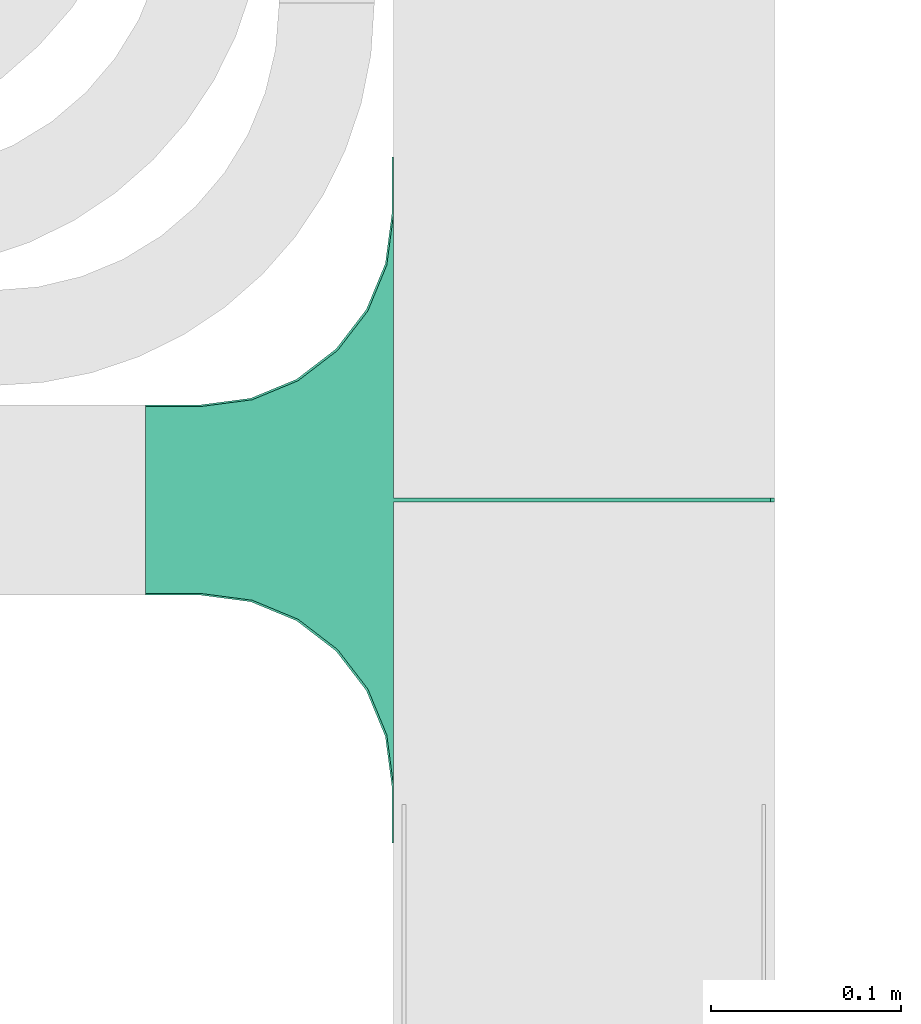
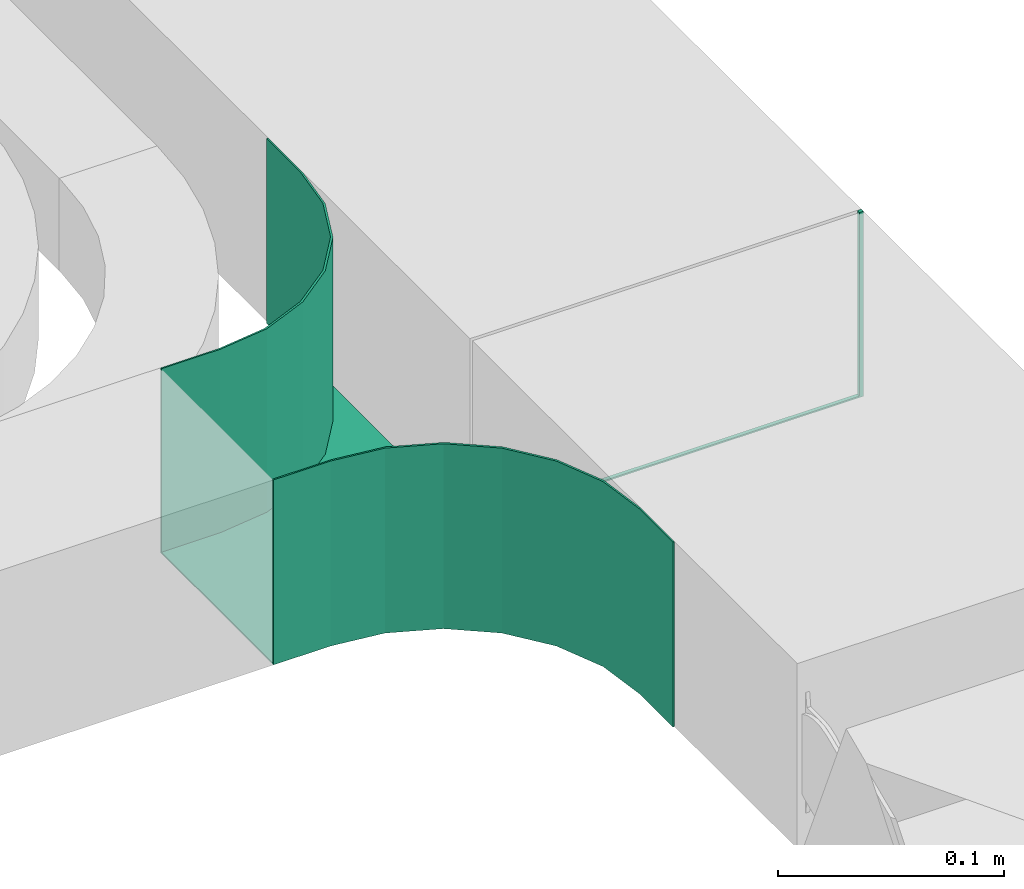
# One storey, part 25 of 25: 1 flow fitting.
"""IFC2X3 building model written with IfcOpenShell, lengths in millimetres."""

from ifc_helpers import new_model, entity, si_unit, converted_unit, derived_unit, direction, frame, origin, place, context, subcontext, project, spatial, faceted_brep, source, transform, mapped, material, type_object, type_shapes, element, save


model = new_model("IFC2X3")

# Units and contexts
model_context = context("Model", 3, precision=0.01, world=origin(), true_north=direction((6.12303176911189e-17, 1.0)))
body_context = subcontext(model_context, "Body", "Model", "MODEL_VIEW")
ifc_project = project(units=[si_unit("LENGTHUNIT", "METRE", prefix="MILLI"), si_unit("AREAUNIT", "SQUARE_METRE"), si_unit("VOLUMEUNIT", "CUBIC_METRE"), converted_unit("PLANEANGLEUNIT", "DEGREE", entity("IfcRatioMeasure", 0.0174532925199433), si_unit("PLANEANGLEUNIT", "RADIAN"), dimensions=[0, 0, 0, 0, 0, 0, 0]), si_unit("MASSUNIT", "GRAM", prefix="KILO"), derived_unit("MASSDENSITYUNIT", [(si_unit("MASSUNIT", "GRAM", prefix="KILO"), 1), (si_unit("LENGTHUNIT", "METRE"), -3)]), derived_unit("MOMENTOFINERTIAUNIT", [(si_unit("LENGTHUNIT", "METRE"), 4)]), si_unit("TIMEUNIT", "SECOND"), si_unit("FREQUENCYUNIT", "HERTZ"), si_unit("THERMODYNAMICTEMPERATUREUNIT", "DEGREE_CELSIUS"), derived_unit("THERMALTRANSMITTANCEUNIT", [(si_unit("MASSUNIT", "GRAM", prefix="KILO"), 1), (si_unit("THERMODYNAMICTEMPERATUREUNIT", "KELVIN"), -1), (si_unit("TIMEUNIT", "SECOND"), -3)]), derived_unit("VOLUMETRICFLOWRATEUNIT", [(si_unit("LENGTHUNIT", "METRE"), 3), (si_unit("TIMEUNIT", "SECOND"), -1)]), derived_unit("MASSFLOWRATEUNIT", [(si_unit("MASSUNIT", "GRAM", prefix="KILO"), 1), (si_unit("TIMEUNIT", "SECOND"), -1)]), derived_unit("ROTATIONALFREQUENCYUNIT", [(si_unit("TIMEUNIT", "SECOND"), -1)]), si_unit("ELECTRICCURRENTUNIT", "AMPERE"), si_unit("ELECTRICVOLTAGEUNIT", "VOLT"), si_unit("POWERUNIT", "WATT"), si_unit("FORCEUNIT", "NEWTON", prefix="KILO"), si_unit("ILLUMINANCEUNIT", "LUX"), si_unit("LUMINOUSFLUXUNIT", "LUMEN"), si_unit("LUMINOUSINTENSITYUNIT", "CANDELA"), derived_unit("USERDEFINED", [(si_unit("MASSUNIT", "GRAM", prefix="KILO"), -1), (si_unit("LENGTHUNIT", "METRE"), -2), (si_unit("TIMEUNIT", "SECOND"), 3), (si_unit("LUMINOUSFLUXUNIT", "LUMEN"), 1)]), derived_unit("LINEARVELOCITYUNIT", [(si_unit("LENGTHUNIT", "METRE"), 1), (si_unit("TIMEUNIT", "SECOND"), -1)]), si_unit("PRESSUREUNIT", "PASCAL"), derived_unit("USERDEFINED", [(si_unit("LENGTHUNIT", "METRE"), -2), (si_unit("MASSUNIT", "GRAM", prefix="KILO"), 1), (si_unit("TIMEUNIT", "SECOND"), -2)]), derived_unit("LINEARFORCEUNIT", [(si_unit("MASSUNIT", "GRAM", prefix="KILO"), 1), (si_unit("LENGTHUNIT", "METRE"), 1), (si_unit("TIMEUNIT", "SECOND"), -2), (si_unit("LENGTHUNIT", "METRE"), -1)]), derived_unit("PLANARFORCEUNIT", [(si_unit("MASSUNIT", "GRAM", prefix="KILO"), 1), (si_unit("LENGTHUNIT", "METRE"), 1), (si_unit("TIMEUNIT", "SECOND"), -2), (si_unit("LENGTHUNIT", "METRE"), -2)])], contexts=[model_context])

# Site, building, storey
site_placement = place(None, frame((0.0, -0.00077364408347762, 0.0)))
site = spatial("IfcSite", under=ifc_project, at=site_placement, CompositionType="ELEMENT")
building_placement = place(site_placement, origin())
building = spatial("IfcBuilding", under=site, at=building_placement, CompositionType="ELEMENT")
storey_placement = place(building_placement, frame((0.0, 0.0, 24000.0)))
storey = spatial("IfcBuildingStorey", under=building, at=storey_placement, CompositionType="ELEMENT", Elevation=24000.0)

# Flow fitting
ifc_material = material()
cable_carrier_fitting_type = type_object("IfcCableCarrierFittingType", PredefinedType="NOTDEFINED", material=ifc_material)
shared_shape = source(origin(), body_context, "Body", "Brep", [
    faceted_brep([(123.318095489757, -103.407417371097, 50.0), (99.2000000000085, -113.39745962156, 50.0), (78.4893218813534, -129.289321881349, 50.0), (62.5974596215641, -150.0, 50.0), (52.6074173711009, -174.118095489752, 50.0), (49.2000000000077, -200.0, 50.0), (49.2000000000077, -230.0, 50.0), (50.0, -230.0, 50.0), (50.0, -200.800000000008, 50.0), (53.4074173711011, -174.918095489754, 50.0), (63.3974596215654, -150.800000000004, 50.0), (79.2893218813565, -130.089321881349, 50.0), (100.0, -114.19745962156, 50.0), (124.118095489764, -104.207417371098, 50.0), (150.0, -100.800000000007, 50.0), (180.0, -100.800000000007, 50.0), (180.0, -100.0, 50.0), (149.200000000009, -100.0, 50.0), (-149.199999999993, -100.0, 50.0), (-180.0, -100.0, 50.0), (-180.0, -100.800000000007, 50.0), (-150.0, -100.800000000007, 50.0), (-124.11809548975, -104.207417371098, 50.0), (-100.0, -114.197459621559, 50.0), (-79.2893218813422, -130.089321881348, 50.0), (-63.3974596215509, -150.800000000004, 50.0), (-53.4074173710865, -174.918095489753, 50.0), (-50.0, -200.800000000007, 50.0), (-50.0, -230.0, 50.0), (-49.1999999999921, -230.0, 50.0), (-49.1999999999921, -200.0, 50.0), (-52.6074173710852, -174.118095489752, 50.0), (-62.5974596215482, -150.0, 50.0), (-78.4893218813374, -129.289321881349, 50.0), (-99.1999999999923, -113.39745962156, 50.0), (-123.31809548974, -103.407417371097, 50.0), (0.0, 100.0, 50.0), (-0.991642077843016, 100.0, 50.0), (-0.991642077843016, 98.0, 50.0), (0.991642077835386, 98.0, 50.0), (0.991642077835386, 100.0, 50.0), (-50.0, -200.800000000007, -50.0), (-53.4074173710865, -174.918095489753, -50.0), (-63.3974596215509, -150.800000000004, -50.0), (-79.2893218813422, -130.089321881348, -50.0), (-100.0, -114.197459621559, -50.0), (-124.11809548975, -104.207417371098, -50.0), (-150.0, -100.800000000007, -50.0), (-180.0, -100.800000000007, -50.0), (-180.0, -100.0, -50.0), (-0.991642077843016, -100.0, -50.0), (-0.991642077843016, 100.0, -50.0), (0.0, 100.0, -50.0), (0.991642077835386, 100.0, -50.0), (0.991642077855545, -100.0, -50.0), (180.0, -100.0, -50.0), (180.0, -100.800000000007, -50.0), (150.0, -100.800000000007, -50.0), (124.118095489764, -104.207417371098, -50.0), (100.0, -114.19745962156, -50.0), (79.2893218813565, -130.089321881349, -50.0), (63.3974596215654, -150.800000000004, -50.0), (53.4074173711011, -174.918095489754, -50.0), (50.0, -200.800000000007, -50.0), (50.0, -230.0, -50.0), (-50.0, -230.0, -50.0), (-50.0, -200.800000000007, -49.1999999999995), (49.2000000000077, -230.0, -49.1999999999995), (-49.1999999999921, -230.0, -49.1999999999995), (-49.1999999999921, -200.0, -49.1999999999995), (-52.6074173710847, -174.118095489754, -49.1999999999995), (-62.5974596215472, -150.0, -49.1999999999995), (-78.489321881336, -129.289321881351, -49.1999999999995), (-99.1999999999908, -113.397459621561, -49.1999999999995), (-123.318095489739, -103.407417371097, -49.1999999999995), (-149.199999999992, -100.0, -49.1999999999995), (-0.991642077843016, -100.0, -49.1999999999995), (0.991642077855537, -100.0, -49.1999999999995), (149.200000000009, -100.0, -49.1999999999995), (-180.0, -100.800000000007, -49.1999999999995), (-150.0, -100.800000000007, -49.1999999999995), (150.0, -100.800000000007, -49.1999999999995), (180.0, -100.800000000007, -49.1999999999995), (50.0, -200.800000000007, -49.1999999999995), (123.318095489757, -103.407417371097, -49.1999999999995), (99.2000000000086, -113.39745962156, -49.1999999999995), (78.4893218813535, -129.289321881349, -49.1999999999995), (62.5974596215642, -150.0, -49.1999999999995), (52.607417371101, -174.118095489751, -49.1999999999995), (49.2000000000077, -200.0, -49.1999999999995), (-0.991642077843016, 98.0, -49.1999999999995), (0.991642077835386, 98.0, -49.1999999999995), (0.0, 100.0, -49.1999999999995)], [[[0, 1, 2, 3, 4, 5, 6, 7, 8, 9, 10, 11, 12, 13, 14, 15, 16, 17]], [[18, 19, 20, 21, 22, 23, 24, 25, 26, 27, 28, 29, 30, 31, 32, 33, 34, 35]], [[36, 37, 38, 39, 40]], [[41, 42, 43, 44, 45, 46, 47, 48, 49, 50, 51, 52, 53, 54, 55, 56, 57, 58, 59, 60, 61, 62, 63, 64, 65]], [[28, 27, 66, 41, 65]], [[29, 28, 65, 64, 7, 6, 67, 68]], [[30, 29, 68, 69]], [[31, 70, 71, 32]], [[32, 71, 72, 33]], [[69, 70, 31, 30]], [[34, 73, 74, 35]], [[35, 74, 75, 18]], [[33, 72, 73, 34]], [[19, 18, 75, 76, 50, 49]], [[16, 55, 54, 77, 78, 17]], [[20, 19, 49, 48, 79]], [[21, 20, 79, 48, 47, 80]], [[15, 14, 81, 57, 56, 82]], [[22, 21, 80, 47, 46]], [[23, 22, 46, 45]], [[45, 44, 24, 23]], [[25, 24, 44, 43]], [[26, 25, 43, 42]], [[27, 26, 42, 41, 66]], [[9, 8, 83, 63, 62]], [[10, 9, 62, 61]], [[11, 10, 61, 60]], [[13, 12, 59, 58]], [[13, 58, 57, 81, 14]], [[59, 12, 11, 60]], [[16, 15, 82, 56, 55]], [[0, 84, 85, 1]], [[1, 85, 86, 2]], [[78, 84, 0, 17]], [[3, 87, 88, 4]], [[4, 88, 89, 5]], [[2, 86, 87, 3]], [[6, 5, 89, 67]], [[8, 7, 64, 63, 83]], [[90, 76, 75, 74, 73, 72, 71, 70, 69, 68, 67, 89, 88, 87, 86, 85, 84, 78, 77, 91]], [[37, 51, 50, 76, 90, 38]], [[39, 38, 90, 91]], [[40, 39, 91, 77, 54, 53]], [[36, 40, 92]], [[37, 36, 92]], [[53, 92, 40]], [[92, 53, 52]], [[92, 52, 51]], [[92, 51, 37]]]),
])
type_shapes(cable_carrier_fitting_type, [shared_shape])
flow_fitting_placement = place(storey_placement, frame((17813.1522790168, 11559.4288730807, 3390.0), z_axis=(0.0, 0.0, 1.0), x_axis=(0.0, -1.0, 0.0)))
element("IfcFlowFitting", 1, at=flow_fitting_placement, inside=storey, type_object=cable_carrier_fitting_type, material=ifc_material, context=body_context, shape_type="MappedRepresentation", body=[
    mapped(shared_shape, transform((0.0, 0.0, 0.0), scale=1.0)),
])

save(model, "model.ifc")
